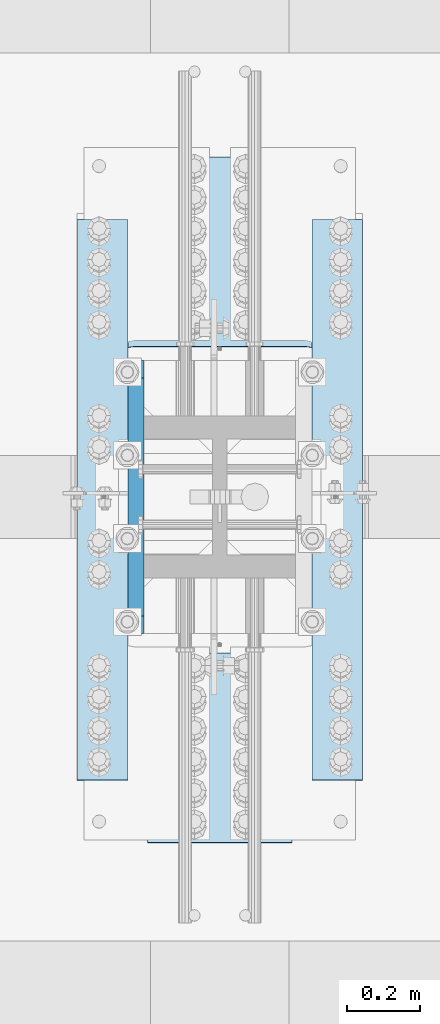
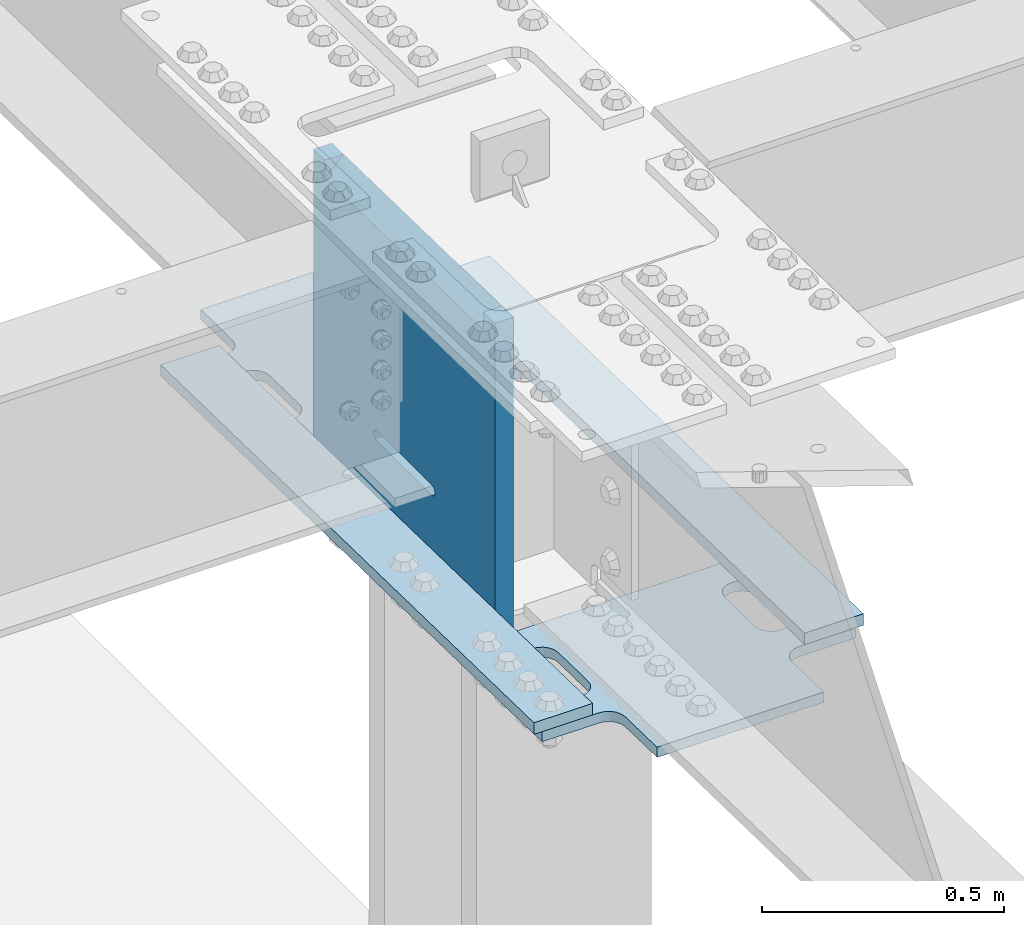
# One storey, part 1416 of 1763: 5 plates, 3 elements without a shape of their own.
"""IFC2X3 building model written with IfcOpenShell, lengths in millimetres."""

from ifc_helpers import new_model, si_unit, frame, origin_with_axes, place, context, subcontext, project, spatial, faceted_brep, material, type_object, element, aggregate, save


model = new_model("IFC2X3")

# Units and contexts
model_context = context("Model", 3, precision=1e-05, world=origin_with_axes())
body_context = subcontext(model_context, "Body", "Model", "MODEL_VIEW")
ifc_project = project(units=[si_unit("LENGTHUNIT", "METRE", prefix="MILLI"), si_unit("AREAUNIT", "SQUARE_METRE"), si_unit("VOLUMEUNIT", "CUBIC_METRE"), si_unit("MASSUNIT", "GRAM", prefix="KILO"), si_unit("TIMEUNIT", "SECOND"), si_unit("PLANEANGLEUNIT", "RADIAN"), si_unit("SOLIDANGLEUNIT", "STERADIAN"), si_unit("THERMODYNAMICTEMPERATUREUNIT", "DEGREE_CELSIUS"), si_unit("LUMINOUSINTENSITYUNIT", "LUMEN")], contexts=[model_context])

# Site, building, storey
site_placement = place(None, origin_with_axes())
site = spatial("IfcSite", under=ifc_project, at=site_placement, CompositionType="ELEMENT")
building_placement = place(site_placement, origin_with_axes())
building = spatial("IfcBuilding", under=site, at=building_placement, Name="Undefined", CompositionType="ELEMENT")
storey_placement = place(building_placement, origin_with_axes())
storey = spatial("IfcBuildingStorey", under=building, at=storey_placement, Name="Undefined", CompositionType="ELEMENT", Elevation=0.0)

# Assembly, plate
assembly_1_placement = place(storey_placement, origin_with_axes())
assembly_1 = element("IfcElementAssembly", 1, at=assembly_1_placement, inside=storey, Name="PLATE", AssemblyPlace="NOTDEFINED", PredefinedType="RIGID_FRAME")
ifc_material = material(Name="STEEL/A572-50")
plate_type_1 = type_object("IfcPlateType", PredefinedType="NOTDEFINED")
plate_1_placement = place(assembly_1_placement, frame((-24400.8345768876, -492.577382211572, 11140.6801475971), z_axis=(0.0, 0.999781542776098, -0.0209013569953182), x_axis=(1.0, 0.0, 0.0)))
plate_1 = element("IfcPlate", 2, at=plate_1_placement, type_object=plate_type_1, material=ifc_material, Name="PLATE", context=body_context, shape_type="Brep", body=[
    faceted_brep([(174.624992193363, -12.7000000001881, 284.187523603282), (174.624992193363, 12.6999999998025, 284.18751402584), (172.682547683828, 12.6999999998097, 271.923402061584), (172.682547683828, -12.700000000179, 271.923411639026), (167.045354157617, 12.6999999998152, 260.859786825482), (167.045354157617, -12.7000000001735, 260.859796402924), (158.265219393721, 12.6999999998225, 252.079652061584), (158.265219393721, -12.7000000001663, 252.079661639026), (147.201604157617, 12.6999999998261, 246.442458535376), (147.201604157617, -12.7000000001626, 246.442468112818), (134.937492193363, 12.6999999998279, 244.50001402584), (134.937492193363, -12.7000000001626, 244.500023603282), (122.673380229109, 12.6999999998261, 246.442458535376), (122.673380229109, -12.7000000001626, 246.442468112818), (111.609764993005, 12.6999999998225, 252.079652061584), (111.609764993005, -12.7000000001663, 252.079661639026), (102.829630229109, 12.6999999998152, 260.859786825482), (102.829630229109, -12.7000000001735, 260.859796402924), (97.1924367028987, 12.6999999998097, 271.923402061584), (97.1924367028987, -12.700000000179, 271.923411639026), (95.2499921933631, 12.6999999998025, 284.18751402584), (95.2499921933631, -12.7000000001881, 284.187523603282), (95.2499921933631, 12.6999999997188, 408.012510974092), (95.2499921933631, -12.7000000002718, 408.012520551534), (97.1924367028987, 12.6999999997097, 420.276622938349), (97.1924367028987, -12.7000000002809, 420.276632515792), (102.829630229109, 12.6999999997024, 431.340238174453), (102.829630229109, -12.7000000002881, 431.340247751895), (111.609764993013, 12.699999999697, 440.120372938351), (111.609764993013, -12.7000000002936, 440.120382515793), (122.673380229116, 12.6999999996915, 445.757566464558), (122.673380229116, -12.7000000002972, 445.757576042), (134.937492193374, 12.6999999996897, 447.700010974091), (134.937492193374, -12.700000000299, 447.700020551534), (147.201604157628, 12.6999999996915, 445.757566464553), (147.201604157628, -12.7000000002972, 445.757576041995), (158.265219393725, 12.699999999697, 440.120372938343), (158.265219393725, -12.7000000002918, 440.120382515786), (167.045354157621, 12.6999999997024, 431.340238174446), (167.045354157621, -12.7000000002881, 431.340247751888), (172.682547683828, 12.6999999997097, 420.276622938345), (172.682547683828, -12.7000000002809, 420.276632515787), (174.624992193363, 12.6999999997188, 408.012510974092), (174.624992193363, -12.7000000002718, 408.012520551534), (172.682547683828, -12.7000000000953, 144.051635563709), (172.682547683828, 12.6999999998952, 144.05163043189), (174.624992193363, 12.6999999999043, 131.787518467636), (174.624992193363, -12.7000000000862, 131.787523599455), (167.045354157621, -12.7000000001008, 155.115250799809), (167.045354157621, 12.6999999998861, 155.11524566799), (158.265219393725, -12.700000000108, 163.895385563706), (158.265219393725, 12.6999999998825, 163.895380431887), (147.201604157624, -12.7000000001099, 169.532579089915), (147.201604157624, 12.6999999998807, 169.532573958096), (134.93749219337, -12.7000000001135, 171.475023599452), (134.93749219337, 12.699999999877, 171.475018467633), (0.0, -12.7000000001117, 171.475023599479), (0.0, 12.699999999877, 171.475018467699), (-3.63797880709171e-12, -12.7000000005737, 854.105041503878), (-3.63797880709171e-12, 12.699999999415, 854.105041503877), (95.2499921932394, -12.7000000005737, 854.105041503878), (95.2499921932394, 12.699999999415, 854.105041503877), (95.2499921932394, -12.7000000003754, 560.412520547623), (95.2499921932394, 12.6999999996151, 560.412520674578), (97.192436702775, -12.7000000003663, 548.148408583368), (97.192436702775, 12.6999999996224, 548.148408710323), (102.829630228985, -12.7000000003572, 537.084793347267), (102.829630228985, 12.6999999996297, 537.084793474222), (111.609764992882, -12.7000000003536, 528.30465858337), (111.609764992882, 12.6999999996369, 528.304658710325), (122.673380228982, -12.7000000003482, 522.667465057162), (122.673380228982, 12.6999999996387, 522.667465184117), (134.937492193239, -12.7000000003482, 520.725020547626), (134.937492193239, 12.6999999996406, 520.725020674581), (611.122306646364, -12.7000000003482, 520.725020547624), (611.122306646364, 12.6999999996406, 520.725020674579), (623.386418610618, -12.7000000003482, 522.66746505716), (623.386418610618, 12.6999999996387, 522.667465184115), (634.450033846722, -12.7000000003536, 528.304658583368), (634.450033846722, 12.6999999996369, 528.304658710323), (643.230168610618, -12.7000000003572, 537.084793347266), (643.230168610618, 12.6999999996297, 537.084793474221), (648.867362136829, -12.7000000003663, 548.148408583367), (648.867362136829, 12.6999999996224, 548.148408710322), (650.809806646364, -12.7000000003754, 560.412520547622), (650.809806646364, 12.6999999996151, 560.412520674577), (650.809806646364, -12.7000000005755, 854.105025430418), (650.809806646364, 12.699999999415, 854.105041503877), (746.059814453125, -12.7000000005737, 854.105041503878), (746.059814453125, 12.699999999415, 854.105041503877), (746.059814453125, -12.7000000001135, 171.475023597528), (746.059814453125, 12.6999999998789, 171.475018465748), (611.122259521497, -12.7000000001135, 171.475023597543), (611.122259521497, 12.699999999877, 171.475018465722), (598.858147557239, -12.7000000001099, 169.532579088008), (598.858147557239, 12.6999999998807, 169.532573956188), (587.794532321135, -12.700000000108, 163.895385561801), (587.794532321135, 12.6999999998807, 163.895380429981), (579.014397557235, -12.700000000099, 155.115250797904), (579.014397557235, 12.699999999888, 155.115245666083), (573.377204031025, -12.7000000000953, 144.051635561802), (573.377204031025, 12.6999999998952, 144.051630429981), (571.434759521489, -12.7000000000862, 131.787523597546), (571.434759521489, 12.6999999999043, 131.787518465725), (571.434759521489, -12.6999999999953, 2.8421709430404e-12), (571.434759521489, 12.6999999999916, 2.50111042987555e-12), (174.624992193363, -12.6999999999953, 9.09494701772928e-13), (174.624992193363, 12.6999999999916, 5.6843418860808e-13), (648.867310257076, -12.700000000179, 271.923411639045), (643.230116730865, -12.7000000001735, 260.859796402943), (634.449981966969, -12.7000000001644, 252.079661639045), (623.386366730865, -12.7000000001644, 246.442468112837), (611.122254766611, -12.7000000001626, 244.500023603301), (598.858142802357, -12.7000000001644, 246.442468112837), (587.794527566253, -12.7000000001644, 252.079661639045), (579.014392802357, -12.7000000001735, 260.859796402943), (573.377199276147, -12.700000000179, 271.923411639045), (571.434754766611, -12.7000000001881, 284.187523603301), (571.434754766611, -12.7000000002718, 408.012520551553), (573.377199276147, -12.700000000279, 420.27663251581), (579.014392802357, -12.7000000002881, 431.340247751913), (587.794527566261, -12.7000000002936, 440.120382515812), (598.858142802364, -12.700000000299, 445.757576042019), (611.122254766622, -12.700000000299, 447.700020551552), (623.386366730876, -12.7000000002972, 445.757576042014), (634.449981966973, -12.7000000002936, 440.120382515804), (643.230116730869, -12.7000000002881, 431.340247751907), (648.867310257076, -12.700000000279, 420.276632515806), (650.809754766611, -12.7000000002718, 408.012520551553), (650.809754766611, -12.7000000001881, 284.187523603301), (643.230116730869, 12.6999999997024, 431.340238174464), (648.867310257076, 12.6999999997097, 420.276622938364), (634.449981966973, 12.699999999697, 440.120372938362), (623.386366730876, 12.6999999996915, 445.757566464571), (611.122254766622, 12.6999999996897, 447.70001097411), (598.858142802364, 12.6999999996915, 445.757566464577), (587.794527566261, 12.699999999697, 440.12037293837), (579.014392802357, 12.6999999997024, 431.340238174471), (573.377199276147, 12.6999999997097, 420.276622938368), (571.434754766611, 12.699999999717, 408.01251097411), (571.434754766611, 12.6999999998025, 284.187514025858), (573.377199276147, 12.6999999998079, 271.923402061603), (579.014392802357, 12.6999999998152, 260.859786825501), (587.794527566253, 12.6999999998225, 252.079652061603), (598.858142802357, 12.6999999998261, 246.442458535395), (611.122254766611, 12.6999999998279, 244.500014025858), (623.386366730865, 12.6999999998261, 246.442458535395), (634.449981966969, 12.6999999998225, 252.079652061603), (643.230116730865, 12.6999999998152, 260.859786825501), (648.867310257076, 12.6999999998079, 271.923402061603), (650.809754766611, 12.6999999998025, 284.187514025858), (650.809754766611, 12.699999999717, 408.01251097411)], [[[0, 1, 2, 3]], [[3, 2, 4, 5]], [[5, 4, 6, 7]], [[7, 6, 8, 9]], [[9, 8, 10, 11]], [[11, 10, 12, 13]], [[13, 12, 14, 15]], [[15, 14, 16, 17]], [[17, 16, 18, 19]], [[19, 18, 20, 21]], [[21, 20, 22, 23]], [[23, 22, 24, 25]], [[25, 24, 26, 27]], [[27, 26, 28, 29]], [[29, 28, 30, 31]], [[31, 30, 32, 33]], [[33, 32, 34, 35]], [[35, 34, 36, 37]], [[37, 36, 38, 39]], [[39, 38, 40, 41]], [[41, 40, 42, 43]], [[43, 42, 1, 0]], [[44, 45, 46, 47]], [[48, 49, 45, 44]], [[50, 51, 49, 48]], [[52, 53, 51, 50]], [[54, 55, 53, 52]], [[56, 57, 55, 54]], [[58, 59, 57, 56]], [[59, 58, 60, 61]], [[60, 62, 63, 61]], [[64, 65, 63, 62]], [[66, 67, 65, 64]], [[68, 69, 67, 66]], [[70, 71, 69, 68]], [[72, 73, 71, 70]], [[74, 75, 73, 72]], [[76, 77, 75, 74]], [[78, 79, 77, 76]], [[80, 81, 79, 78]], [[82, 83, 81, 80]], [[84, 85, 83, 82]], [[86, 87, 85, 84]], [[88, 89, 87, 86]], [[89, 88, 90, 91]], [[90, 92, 93, 91]], [[94, 95, 93, 92]], [[96, 97, 95, 94]], [[98, 99, 97, 96]], [[100, 101, 99, 98]], [[102, 103, 101, 100]], [[104, 105, 103, 102]], [[105, 104, 106, 107]], [[47, 46, 107, 106]], [[104, 102, 100, 98, 96, 94, 92, 90, 88, 86, 84, 82, 80, 78, 76, 74, 72, 70, 68, 66, 64, 62, 60, 58, 56, 54, 52, 50, 48, 44, 47, 106], [3, 5, 7, 9, 11, 13, 15, 17, 19, 21, 23, 25, 27, 29, 31, 33, 35, 37, 39, 41, 43, 0], [108, 109, 110, 111, 112, 113, 114, 115, 116, 117, 118, 119, 120, 121, 122, 123, 124, 125, 126, 127, 128, 129]], [[126, 130, 131, 127]], [[125, 132, 130, 126]], [[124, 133, 132, 125]], [[123, 134, 133, 124]], [[122, 135, 134, 123]], [[121, 136, 135, 122]], [[120, 137, 136, 121]], [[119, 138, 137, 120]], [[118, 139, 138, 119]], [[117, 140, 139, 118]], [[116, 141, 140, 117]], [[115, 142, 141, 116]], [[114, 143, 142, 115]], [[113, 144, 143, 114]], [[112, 145, 144, 113]], [[111, 146, 145, 112]], [[110, 147, 146, 111]], [[109, 148, 147, 110]], [[108, 149, 148, 109]], [[129, 150, 149, 108]], [[128, 151, 150, 129]], [[127, 131, 151, 128]], [[49, 51, 53, 55, 57, 59, 61, 63, 65, 67, 69, 71, 73, 75, 77, 79, 81, 83, 85, 87, 89, 91, 93, 95, 97, 99, 101, 103, 105, 107, 46, 45], [38, 36, 34, 32, 30, 28, 26, 24, 22, 20, 18, 16, 14, 12, 10, 8, 6, 4, 2, 1, 42, 40], [130, 132, 133, 134, 135, 136, 137, 138, 139, 140, 141, 142, 143, 144, 145, 146, 147, 148, 149, 150, 151, 131]]]),
])
aggregate(assembly_1, [plate_1])

assembly_2_placement = place(storey_placement, origin_with_axes())
assembly_2 = element("IfcElementAssembly", 3, at=assembly_2_placement, inside=storey, Name="PLATE", AssemblyPlace="NOTDEFINED", PredefinedType="RIGID_FRAME")
plate_2_placement = place(assembly_2_placement, frame((-24400.8345768876, 536.335762369295, 11119.1696894869), z_axis=(0.0, 0.999781542776098, -0.0209013569953182), x_axis=(1.0, 0.0, 0.0)))
plate_2 = element("IfcPlate", 4, at=plate_2_placement, type_object=plate_type_1, material=ifc_material, Name="PLATE", context=body_context, shape_type="Brep", body=[
    faceted_brep([(174.624992193356, -12.6999999998898, 446.092506445763), (174.624992193356, 12.7000000001244, 446.092506445769), (172.68254768382, 12.7000000001208, 433.828394481514), (172.68254768382, -12.6999999998916, 433.828394481508), (167.045354157613, 12.7000000001171, 422.764779245412), (167.045354157613, -12.6999999998952, 422.764779245407), (158.265219393714, 12.7000000001135, 413.984644481515), (158.265219393714, -12.699999999897, 413.98464448151), (147.201604157613, 12.7000000001135, 408.347450955307), (147.201604157613, -12.6999999999007, 408.347450955302), (134.937492193356, 12.7000000001135, 406.405006445771), (134.937492193356, -12.6999999999007, 406.405006445766), (122.673380229109, 12.7000000001135, 408.347450955307), (122.673380229109, -12.6999999999007, 408.347450955302), (111.609764993005, 12.7000000001135, 413.984644481515), (111.609764993005, -12.699999999897, 413.98464448151), (102.829630229109, 12.7000000001171, 422.764779245413), (102.829630229109, -12.6999999998952, 422.764779245408), (97.1924367028987, 12.7000000001208, 433.828394481515), (97.1924367028987, -12.6999999998916, 433.828394481509), (95.2499921933631, 12.7000000001244, 446.09250644577), (95.2499921933631, -12.6999999998898, 446.092506445764), (95.2499921933631, 12.7000000001553, 569.917503394017), (95.2499921933631, -12.699999999857, 569.917503394012), (97.1924367028987, 12.700000000159, 582.181615358274), (97.1924367028987, -12.6999999998534, 582.181615358269), (102.829630229109, 12.7000000001626, 593.245230594377), (102.829630229109, -12.6999999998498, 593.245230594371), (111.609764993009, 12.7000000001644, 602.025365358275), (111.609764993009, -12.6999999998479, 602.025365358269), (122.673380229113, 12.7000000001663, 607.662558884482), (122.673380229113, -12.6999999998479, 607.662558884477), (134.93749219337, 12.7000000001663, 609.605003394016), (134.93749219337, -12.6999999998461, 609.60500339401), (147.201604157624, 12.7000000001663, 607.662558884477), (147.201604157624, -12.6999999998479, 607.662558884472), (158.265219393725, 12.7000000001644, 602.025365358268), (158.265219393725, -12.6999999998479, 602.025365358263), (167.045354157621, 12.7000000001626, 593.24523059437), (167.045354157621, -12.6999999998498, 593.245230594365), (172.682547683828, 12.700000000159, 582.181615358269), (172.682547683828, -12.6999999998534, 582.181615358264), (174.624992193363, 12.7000000001553, 569.917503394016), (174.624992193363, -12.699999999857, 569.91750339401), (571.434759521486, -12.6999999997843, 854.105041503864), (571.434759521486, 12.7000000002317, 854.105041503864), (174.62499219336, 12.7000000002317, 854.105041503864), (174.62499219336, -12.6999999997843, 854.105041503864), (571.434759521486, -12.699999999817, 722.317504279076), (571.434759521486, 12.7000000001972, 722.317517769904), (573.377204031021, -12.6999999998206, 710.053392314819), (573.377204031021, 12.7000000001917, 710.053405805647), (579.014397557232, -12.6999999998225, 698.989777078716), (579.014397557232, 12.7000000001917, 698.989790569544), (587.794532321128, -12.6999999998243, 690.209642314817), (587.794532321128, 12.7000000001881, 690.209655805645), (598.858147557232, -12.6999999998261, 684.572448788608), (598.858147557232, 12.7000000001863, 684.572462279436), (611.122259521486, -12.6999999998261, 682.630004279072), (611.122259521486, 12.7000000001863, 682.6300177699), (746.059814453125, -12.6999999998261, 682.630004279072), (746.059814453125, 12.7000000001863, 682.630017769905), (746.059814453125, -12.700000000008, 4.37694325228222e-12), (746.059814453125, 12.700000000008, 3.69482222595252e-12), (650.809806646488, -12.700000000008, 3.80850906367414e-12), (650.809806646488, 12.700000000008, 3.24007487506606e-12), (650.809806646488, -12.6999999999298, 293.692504279435), (650.809806646488, 12.7000000000844, 293.692504457733), (648.867362136953, -12.6999999999261, 305.95661624369), (648.867362136953, 12.7000000000862, 305.956616421988), (643.230168610742, -12.6999999999243, 317.020231479791), (643.230168610742, 12.700000000088, 317.020231658089), (634.450033846846, -12.6999999999225, 325.800366243688), (634.450033846846, 12.7000000000917, 325.800366421986), (623.386418610742, -12.6999999999189, 331.437559769896), (623.386418610742, 12.7000000000935, 331.437559948194), (611.122306646488, -12.6999999999207, 333.380004279432), (611.122306646488, 12.7000000000935, 333.38000445773), (134.937492193367, -12.6999999999207, 333.380004279432), (134.937492193367, 12.7000000000935, 333.38000445773), (122.673380229109, -12.6999999999189, 331.437559769896), (122.673380229109, 12.7000000000935, 331.437559948194), (111.609764993009, -12.6999999999225, 325.800366243688), (111.609764993009, 12.7000000000917, 325.800366421986), (102.829630229109, -12.6999999999243, 317.020231479791), (102.829630229109, 12.700000000088, 317.020231658089), (97.1924367029023, -12.699999999928, 305.95661624369), (97.1924367029023, 12.7000000000862, 305.956616421988), (95.2499921933668, -12.6999999999298, 293.692504279436), (95.2499921933668, 12.7000000000844, 293.692504457734), (95.2499921933631, -12.700000000008, 8.5265128291212e-13), (95.2499921933631, 12.700000000008, 2.8421709430404e-13), (0.0, -12.6999999999971, -1.81898940354586e-12), (0.0, 12.6999999999971, -1.81898940354586e-12), (-3.63797880709171e-12, -12.6999999998279, 682.630004279216), (-3.63797880709171e-12, 12.7000000001863, 682.630017770049), (134.937492193352, -12.6999999998279, 682.630004279215), (134.937492193352, 12.7000000001863, 682.630017770043), (147.20160415761, -12.6999999998261, 684.572448788752), (147.20160415761, 12.7000000001844, 684.572462279579), (158.26521939371, -12.6999999998261, 690.20964231496), (158.26521939371, 12.7000000001881, 690.209655805788), (167.04535415761, -12.6999999998225, 698.989777078859), (167.04535415761, 12.7000000001899, 698.989790569686), (172.682547683817, -12.6999999998206, 710.053392314961), (172.682547683817, 12.7000000001935, 710.053405805789), (174.624992193352, -12.6999999998152, 722.317504279218), (174.624992193352, 12.7000000001972, 722.317517770045), (648.867310257068, -12.6999999998916, 433.828394481527), (643.230116730861, -12.6999999998934, 422.764779245426), (634.449981966962, -12.699999999897, 413.984644481528), (623.386366730861, -12.6999999998989, 408.34745095532), (611.122254766604, -12.6999999999007, 406.405006445784), (598.858142802357, -12.6999999998989, 408.347450955321), (587.794527566253, -12.699999999897, 413.984644481529), (579.014392802357, -12.6999999998934, 422.764779245427), (573.377199276147, -12.6999999998916, 433.828394481528), (571.434754766611, -12.6999999998898, 446.092506445783), (571.434754766611, -12.6999999998552, 569.91750339403), (573.377199276147, -12.6999999998534, 582.181615358287), (579.014392802357, -12.6999999998516, 593.24523059439), (587.794527566257, -12.6999999998498, 602.025365358288), (598.858142802361, -12.6999999998479, 607.662558884495), (611.122254766618, -12.6999999998461, 609.605003394029), (623.386366730872, -12.6999999998479, 607.662558884491), (634.449981966973, -12.6999999998498, 602.025365358281), (643.230116730869, -12.6999999998498, 593.245230594383), (648.867310257076, -12.6999999998534, 582.181615358283), (650.809754766611, -12.6999999998552, 569.917503394029), (650.809754766604, -12.6999999998898, 446.092506445782), (643.230116730869, 12.7000000001626, 593.245230594389), (648.867310257076, 12.7000000001608, 582.181615358288), (634.449981966973, 12.7000000001663, 602.025365358287), (623.386366730872, 12.7000000001644, 607.662558884496), (611.122254766618, 12.7000000001663, 609.605003394035), (598.858142802361, 12.7000000001644, 607.6625588845), (587.794527566257, 12.7000000001663, 602.025365358293), (579.014392802357, 12.7000000001626, 593.245230594395), (573.377199276147, 12.7000000001608, 582.181615358293), (571.434754766611, 12.7000000001553, 569.917503394036), (571.434754766611, 12.7000000001244, 446.092506445789), (573.377199276147, 12.7000000001208, 433.828394481533), (579.014392802357, 12.7000000001171, 422.764779245432), (587.794527566253, 12.7000000001153, 413.984644481534), (598.858142802357, 12.7000000001135, 408.347450955326), (611.122254766604, 12.7000000001135, 406.40500644579), (623.386366730861, 12.7000000001135, 408.347450955326), (634.449981966962, 12.7000000001153, 413.984644481534), (643.230116730861, 12.7000000001171, 422.764779245431), (648.867310257068, 12.7000000001208, 433.828394481532), (650.809754766604, 12.7000000001244, 446.092506445787), (650.809754766611, 12.7000000001553, 569.917503394034)], [[[0, 1, 2, 3]], [[3, 2, 4, 5]], [[5, 4, 6, 7]], [[7, 6, 8, 9]], [[9, 8, 10, 11]], [[11, 10, 12, 13]], [[13, 12, 14, 15]], [[15, 14, 16, 17]], [[17, 16, 18, 19]], [[19, 18, 20, 21]], [[21, 20, 22, 23]], [[23, 22, 24, 25]], [[25, 24, 26, 27]], [[27, 26, 28, 29]], [[29, 28, 30, 31]], [[31, 30, 32, 33]], [[33, 32, 34, 35]], [[35, 34, 36, 37]], [[37, 36, 38, 39]], [[39, 38, 40, 41]], [[41, 40, 42, 43]], [[43, 42, 1, 0]], [[44, 45, 46, 47]], [[44, 48, 49, 45]], [[50, 51, 49, 48]], [[52, 53, 51, 50]], [[54, 55, 53, 52]], [[56, 57, 55, 54]], [[58, 59, 57, 56]], [[60, 61, 59, 58]], [[62, 63, 61, 60]], [[63, 62, 64, 65]], [[66, 67, 65, 64]], [[68, 69, 67, 66]], [[70, 71, 69, 68]], [[72, 73, 71, 70]], [[74, 75, 73, 72]], [[76, 77, 75, 74]], [[78, 79, 77, 76]], [[80, 81, 79, 78]], [[82, 83, 81, 80]], [[84, 85, 83, 82]], [[86, 87, 85, 84]], [[88, 89, 87, 86]], [[90, 91, 89, 88]], [[92, 93, 91, 90]], [[93, 92, 94, 95]], [[96, 97, 95, 94]], [[98, 99, 97, 96]], [[100, 101, 99, 98]], [[102, 103, 101, 100]], [[104, 105, 103, 102]], [[106, 107, 105, 104]], [[47, 46, 107, 106]], [[104, 102, 100, 98, 96, 94, 92, 90, 88, 86, 84, 82, 80, 78, 76, 74, 72, 70, 68, 66, 64, 62, 60, 58, 56, 54, 52, 50, 48, 44, 47, 106], [3, 5, 7, 9, 11, 13, 15, 17, 19, 21, 23, 25, 27, 29, 31, 33, 35, 37, 39, 41, 43, 0], [108, 109, 110, 111, 112, 113, 114, 115, 116, 117, 118, 119, 120, 121, 122, 123, 124, 125, 126, 127, 128, 129]], [[126, 130, 131, 127]], [[125, 132, 130, 126]], [[124, 133, 132, 125]], [[123, 134, 133, 124]], [[122, 135, 134, 123]], [[121, 136, 135, 122]], [[120, 137, 136, 121]], [[119, 138, 137, 120]], [[118, 139, 138, 119]], [[117, 140, 139, 118]], [[116, 141, 140, 117]], [[115, 142, 141, 116]], [[114, 143, 142, 115]], [[113, 144, 143, 114]], [[112, 145, 144, 113]], [[111, 146, 145, 112]], [[110, 147, 146, 111]], [[109, 148, 147, 110]], [[108, 149, 148, 109]], [[129, 150, 149, 108]], [[128, 151, 150, 129]], [[127, 131, 151, 128]], [[45, 49, 51, 53, 55, 57, 59, 61, 63, 65, 67, 69, 71, 73, 75, 77, 79, 81, 83, 85, 87, 89, 91, 93, 95, 97, 99, 101, 103, 105, 107, 46], [38, 36, 34, 32, 30, 28, 26, 24, 22, 20, 18, 16, 14, 12, 10, 8, 6, 4, 2, 1, 42, 40], [130, 132, 133, 134, 135, 136, 137, 138, 139, 140, 141, 142, 143, 144, 145, 146, 147, 148, 149, 150, 151, 131]]]),
])
aggregate(assembly_2, [plate_2])

# Assembly, plates
assembly_3_placement = place(storey_placement, origin_with_axes())
assembly_3 = element("IfcElementAssembly", 5, at=assembly_3_placement, inside=storey, Name="COLUMN", AssemblyPlace="NOTDEFINED", PredefinedType="RIGID_FRAME")
plate_type_2 = type_object("IfcPlateType", PredefinedType="NOTDEFINED")
plate_3_placement = place(assembly_3_placement, frame((-24280.2497616161, 1219.39572323053, 11131.8830892076), z_axis=(0.0, -0.999781542838788, 0.0209013539966307), x_axis=(-1.0, 0.0, 0.0)))
plate_3 = element("IfcPlate", 6, at=plate_3_placement, type_object=plate_type_2, material=ifc_material, Name="PLATE", context=body_context, shape_type="Brep", body=[
    faceted_brep([(0.0, -14.2875000000058, 0.0), (-8.88576323632151e-08, -14.2875000006625, 1540.32299804674), (-8.88103386387229e-08, 14.2874999993546, 1540.32299804674), (0.0, 14.2875000000058, 0.0), (139.699996946896, -14.2875000007316, 1540.32299804674), (139.699996946943, 14.2874999992855, 1540.32299804674), (139.700000000004, -14.2875000000004, 0.0), (139.700000000004, 14.2875000000004, 0.0)], [[[0, 1, 2, 3]], [[1, 4, 5, 2]], [[4, 6, 7, 5]], [[0, 3, 7, 6]], [[5, 7, 3, 2]], [[6, 4, 1, 0]]]),
])
plate_4_placement = place(assembly_3_placement, frame((-23635.7247738064, 1219.39572361073, 11131.8830896644), z_axis=(0.0, -0.999781542838788, 0.0209013539966307), x_axis=(-1.0, 0.0, 0.0)))
plate_4 = element("IfcPlate", 7, at=plate_4_placement, type_object=plate_type_2, material=ifc_material, Name="PLATE", context=body_context, shape_type="Brep", body=[
    faceted_brep([(0.0, -14.2875000000058, 0.0), (-8.88576323632151e-08, -14.2875000006625, 1540.32299804674), (-8.88103386387229e-08, 14.2874999993546, 1540.32299804674), (0.0, 14.2875000000058, 0.0), (139.699996946896, -14.2875000007316, 1540.32299804674), (139.699996946943, 14.2874999992855, 1540.32299804674), (139.700000000004, -14.2875000000004, 0.0), (139.700000000004, 14.2875000000004, 0.0)], [[[0, 1, 2, 3]], [[1, 4, 5, 2]], [[4, 6, 7, 5]], [[0, 3, 7, 6]], [[5, 7, 3, 2]], [[6, 4, 1, 0]]]),
])
plate_type_3 = type_object("IfcPlateType", PredefinedType="NOTDEFINED")
plate_5_placement = place(assembly_3_placement, frame((-24258.0247736984, 82.5499999999987, 11908.396171495), z_axis=(0.0, 0.0, -1.0), x_axis=(0.0, 1.0, 0.0)))
plate_5 = element("IfcPlate", 8, at=plate_5_placement, type_object=plate_type_3, material=ifc_material, Name="PLATE", context=body_context, shape_type="Brep", body=[
    faceted_brep([(47.6145959295905, -22.2249999999985, 18.5685075206347), (47.6145959295905, 22.2249999999985, 18.5685075206347), (46.6855284141526, -22.2250000000386, 63.0087977831517), (701.521713312289, 22.2249999999985, 32.2390721115407), (700.592645796853, -22.2250000000386, 76.6793623739632), (701.521713328887, -22.2250007531729, 32.2390713176028), (-1.56319401867222e-13, -22.2249999999985, 17.5730780600552), (-1.56319401867222e-13, 22.2249999999985, 17.5730780600552), (-7.27595761418343e-12, -22.2249999999985, 855.715637207031), (-7.27595761418343e-12, 22.2249999999985, 855.715637207031), (749.300048828125, -22.2249999999985, 855.715637207031), (749.300048828125, 22.2249999999985, 855.715637207031), (749.300048828125, -22.2249999999985, 33.2379247075005), (749.300048828125, 22.2249999999985, 33.2379247075005), (497.930265062582, 22.2249999999985, 604.292756176623), (493.810088594428, 22.2249999999985, 607.045770077102), (488.950009076383, 22.2249999999985, 608.01249999969), (260.350008694913, 22.2249999999985, 608.012499999682), (255.489929176868, 22.2249999999985, 607.045770077095), (251.369752708714, 22.2249999999985, 604.292756176617), (248.616738808236, 22.2249999999985, 600.172579708464), (247.650008885648, 22.2249999999985, 595.312500190417), (248.616738808236, 22.2249999999985, 590.452420672371), (251.369752708714, 22.2249999999985, 586.332244204217), (255.489929176868, 22.2249999999985, 583.57923030374), (260.350008694913, 22.2249999999985, 582.612500381152), (488.950009076383, 22.2249999999985, 582.612500381152), (493.810088594429, 22.2249999999985, 583.57923030374), (497.930265062582, 22.2249999999985, 586.332244204217), (500.68327896306, 22.2249999999985, 590.452420672371), (501.650008885648, 22.2249999999985, 595.312500190417), (500.68327896306, 22.2249999999985, 600.172579708469), (500.68327896306, -22.2249999999985, 600.172579708469), (501.650008885648, -22.2249999999985, 595.312500190417), (497.930265062582, -22.2249999999985, 604.292756176623), (493.810088594428, -22.2249999999985, 607.045770077102), (488.950009076383, -22.2249999999985, 608.01249999969), (260.350008694913, -22.2249999999985, 608.012499999682), (255.489929176868, -22.2249999999985, 607.045770077095), (251.369752708714, -22.2249999999985, 604.292756176617), (248.616738808236, -22.2249999999985, 600.172579708464), (247.650008885648, -22.2249999999985, 595.312500190417), (248.616738808236, -22.2249999999985, 590.452420672371), (251.369752708714, -22.2249999999985, 586.332244204217), (255.489929176868, -22.2249999999985, 583.57923030374), (260.350008694913, -22.2249999999985, 582.612500381152), (488.950009076383, -22.2249999999985, 582.612500381152), (493.810088594429, -22.2249999999985, 583.57923030374), (497.930265062582, -22.2249999999985, 586.332244204217), (500.68327896306, -22.2249999999985, 590.452420672371)], [[[0, 1, 2]], [[3, 4, 2, 1]], [[5, 4, 3]], [[6, 7, 1, 0]], [[8, 9, 7, 6]], [[8, 10, 11, 9]], [[11, 10, 12, 13]], [[13, 12, 5, 3]], [[7, 9, 11, 13, 3, 1], [14, 15, 16, 17, 18, 19, 20, 21, 22, 23, 24, 25, 26, 27, 28, 29, 30, 31]], [[32, 31, 30, 33]], [[34, 14, 31, 32]], [[35, 15, 14, 34]], [[36, 16, 15, 35]], [[37, 17, 16, 36]], [[38, 18, 17, 37]], [[39, 19, 18, 38]], [[40, 20, 19, 39]], [[41, 21, 20, 40]], [[42, 22, 21, 41]], [[43, 23, 22, 42]], [[44, 24, 23, 43]], [[45, 25, 24, 44]], [[46, 26, 25, 45]], [[47, 27, 26, 46]], [[48, 28, 27, 47]], [[49, 29, 28, 48]], [[33, 30, 29, 49]], [[12, 10, 8, 6, 0, 2, 4, 5], [48, 47, 46, 45, 44, 43, 42, 41, 40, 39, 38, 37, 36, 35, 34, 32, 33, 49]]]),
])
aggregate(assembly_3, [plate_3, plate_4, plate_5])

save(model, "model.ifc")
